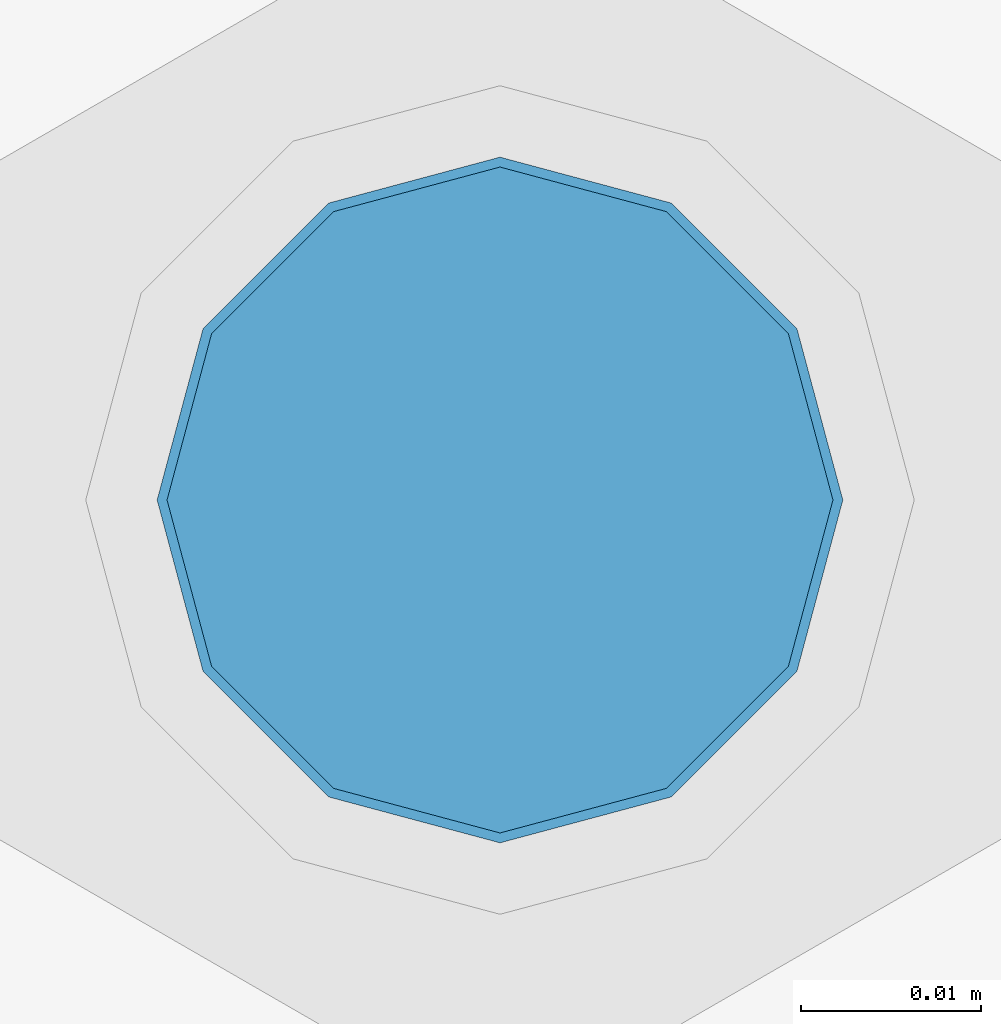
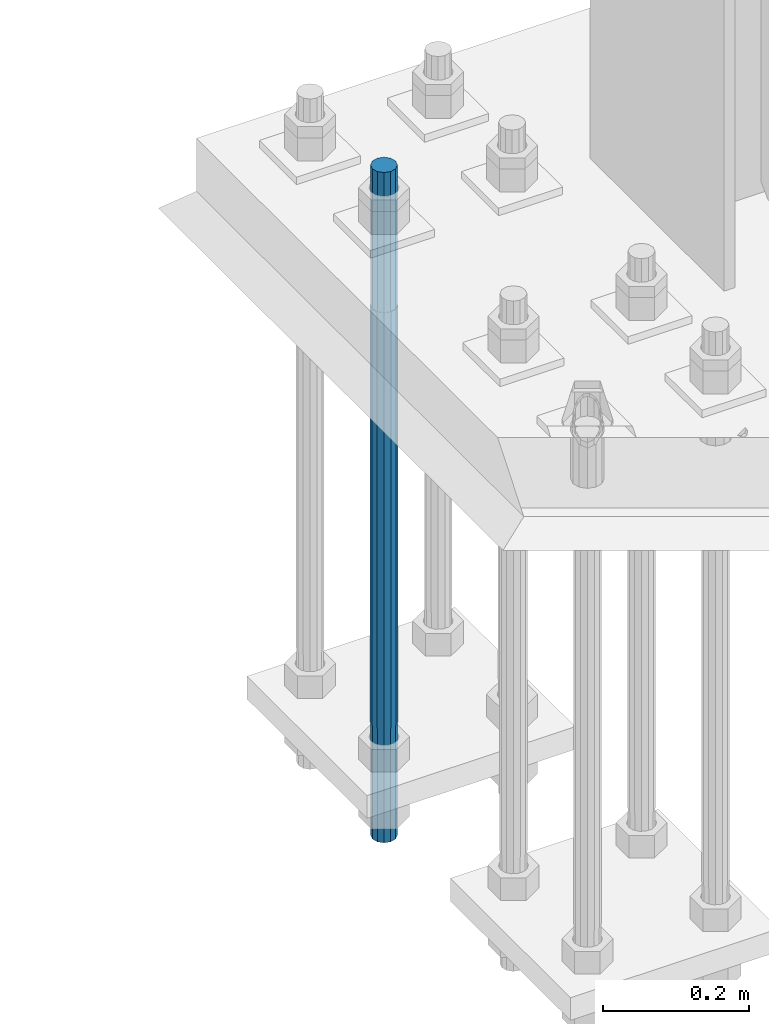
# One storey, part 1403 of 3843: 1 column, 1 element without a shape of its own.
"""IFC2X3 building model written with IfcOpenShell, lengths in millimetres."""

from ifc_helpers import new_model, si_unit, frame, origin_with_axes, place, context, subcontext, project, spatial, faceted_brep, material, type_object, element, aggregate, save


model = new_model("IFC2X3")

# Units and contexts
model_context = context("Model", 3, precision=1e-05, world=origin_with_axes())
body_context = subcontext(model_context, "Body", "Model", "MODEL_VIEW")
ifc_project = project(units=[si_unit("LENGTHUNIT", "METRE", prefix="MILLI"), si_unit("AREAUNIT", "SQUARE_METRE"), si_unit("VOLUMEUNIT", "CUBIC_METRE"), si_unit("MASSUNIT", "GRAM", prefix="KILO"), si_unit("TIMEUNIT", "SECOND"), si_unit("PLANEANGLEUNIT", "RADIAN"), si_unit("SOLIDANGLEUNIT", "STERADIAN"), si_unit("THERMODYNAMICTEMPERATUREUNIT", "DEGREE_CELSIUS"), si_unit("LUMINOUSINTENSITYUNIT", "LUMEN")], contexts=[model_context])

# Site, building, storey
site_placement = place(None, origin_with_axes())
site = spatial("IfcSite", under=ifc_project, at=site_placement, CompositionType="ELEMENT")
building_placement = place(site_placement, origin_with_axes())
building = spatial("IfcBuilding", under=site, at=building_placement, Name="Undefined", CompositionType="ELEMENT")
storey_placement = place(building_placement, origin_with_axes())
storey = spatial("IfcBuildingStorey", under=building, at=storey_placement, Name="Undefined", CompositionType="ELEMENT", Elevation=0.0)

# Assembly, column
assembly_placement = place(storey_placement, origin_with_axes())
assembly = element("IfcElementAssembly", 1, at=assembly_placement, inside=storey, Name="TEMPLATE", AssemblyPlace="NOTDEFINED", PredefinedType="RIGID_FRAME")
ifc_material = material(Name="Undefined/F1554-GR.55")
column_type = type_object("IfcColumnType", PredefinedType="NOTDEFINED")
column_placement = place(assembly_placement, frame((76504.8, 104736.9, 29565.6), z_axis=(-1.0, 0.0, 0.0), x_axis=(0.0, 0.0, -1.0)))
column = element("IfcColumn", 2, at=column_placement, type_object=column_type, material=ifc_material, Name="ANCHOR_ROD", context=body_context, shape_type="Brep", body=[
    faceted_brep([(-234.950000000001, -16.0214699700155, 9.25), (-234.950000000001, -9.25, 16.0214699700155), (-234.950000000001, 0.0, 18.5), (-234.950000000001, 9.25, 16.0214699700155), (-234.950000000001, 16.0214699700155, 9.25), (-234.950000000001, 18.5, 0.0), (-234.950000000001, 16.0214699700155, -9.25), (-234.950000000001, 9.25, -16.0214699700155), (-234.950000000001, 0.0, -18.5), (-234.950000000001, -9.25, -16.0214699700155), (-234.950000000001, -16.0214699700155, -9.25), (-234.950000000001, -18.5, 0.0), (0.0, 18.5, 0.0), (0.0, 16.0214699700118, -9.25), (0.0, 9.25, -16.0214699700155), (0.0, 0.0, -18.5), (0.0, -9.25, -16.0214699700155), (0.0, -16.0214699700118, -9.25), (0.0, -18.5, 0.0), (0.0, -16.0214699700118, 9.25), (0.0, -9.25, 16.0214699700155), (0.0, 0.0, 18.5), (0.0, 9.25, 16.0214699700155), (0.0, 16.0214699700118, 9.25), (0.0, -16.4977839420972, 9.52500000000146), (0.0, -9.52500000000146, 16.4977839420972), (0.0, 0.0, 19.0499989999989), (0.0, 9.52500000000146, 16.4977839420972), (0.0, 16.4977839420972, 9.52500000000146), (0.0, 19.0500000000029, 0.0), (0.0, 16.4977839420972, -9.52500000000146), (0.0, 9.52500000000146, -16.4977839420972), (0.0, 0.0, -19.0499989999989), (0.0, -9.52500000000146, -16.4977839420972), (0.0, -16.4977839420972, -9.52500000000146), (0.0, -19.0500000000029, 0.0), (698.5, -19.0499999999993, 0.0), (698.5, -16.4977839420935, 9.52499999999418), (698.5, -9.52500000000146, 16.4977839420899), (698.5, 0.0, 19.0500000000029), (698.5, 9.52500000000146, 16.4977839420899), (698.5, 16.4977839420935, 9.52499999999418), (698.5, 19.0499999999993, 0.0), (698.5, 16.4977839420935, -9.52499999999418), (698.5, 9.52500000000146, -16.4977839420899), (698.5, 0.0, -19.0500000000029), (698.5, -9.52500000000146, -16.4977839420899), (698.5, -16.4977839420935, -9.52499999999418), (698.5, -9.25, 16.0214699700155), (698.5, 0.0, 18.5), (698.5, 9.25, 16.0214699700155), (698.5, 16.0214699700118, 9.25), (698.5, 18.5, 0.0), (698.5, 16.0214699700118, -9.25), (698.5, 9.25, -16.0214699700155), (698.5, 0.0, -18.5), (698.5, -9.25, -16.0214699700155), (698.5, -16.0214699700118, -9.25), (698.5, -18.5, 0.0), (698.5, -16.0214699700118, 9.25), (889.0, -9.25, -16.0214699700155), (889.0, 0.0, -18.5), (889.0, 9.25, -16.0214699700155), (889.0, 16.0214699700118, -9.25), (889.0, 18.5, 0.0), (889.0, 16.0214699700118, 9.25), (889.0, 9.25, 16.0214699700155), (889.0, 0.0, 18.5), (889.0, -9.25, 16.0214699700155), (889.0, -16.0214699700118, 9.25), (889.0, -18.5, 0.0), (889.0, -16.0214699700118, -9.25)], [[[0, 1, 2, 3, 4, 5, 6, 7, 8, 9, 10, 11]], [[6, 5, 12, 13]], [[7, 6, 13, 14]], [[8, 7, 14, 15]], [[9, 8, 15, 16]], [[10, 9, 16, 17]], [[11, 10, 17, 18]], [[0, 11, 18, 19]], [[1, 0, 19, 20]], [[2, 1, 20, 21]], [[3, 2, 21, 22]], [[4, 3, 22, 23]], [[5, 4, 23, 12]], [[24, 25, 26, 27, 28, 29, 30, 31, 32, 33, 34, 35], [22, 21, 20, 19, 18, 17, 16, 15, 14, 13, 12, 23]], [[24, 35, 36, 37]], [[25, 24, 37, 38]], [[26, 25, 38, 39]], [[27, 26, 39, 40]], [[28, 27, 40, 41]], [[29, 28, 41, 42]], [[30, 29, 42, 43]], [[31, 30, 43, 44]], [[32, 31, 44, 45]], [[33, 32, 45, 46]], [[34, 33, 46, 47]], [[35, 34, 47, 36]], [[46, 45, 44, 43, 42, 41, 40, 39, 38, 37, 36, 47], [48, 49, 50, 51, 52, 53, 54, 55, 56, 57, 58, 59]], [[60, 61, 62, 63, 64, 65, 66, 67, 68, 69, 70, 71]], [[68, 67, 49, 48]], [[69, 68, 48, 59]], [[70, 69, 59, 58]], [[71, 70, 58, 57]], [[60, 71, 57, 56]], [[61, 60, 56, 55]], [[62, 61, 55, 54]], [[63, 62, 54, 53]], [[64, 63, 53, 52]], [[65, 64, 52, 51]], [[66, 65, 51, 50]], [[67, 66, 50, 49]]]),
])
aggregate(assembly, [column])

save(model, "model.ifc")
